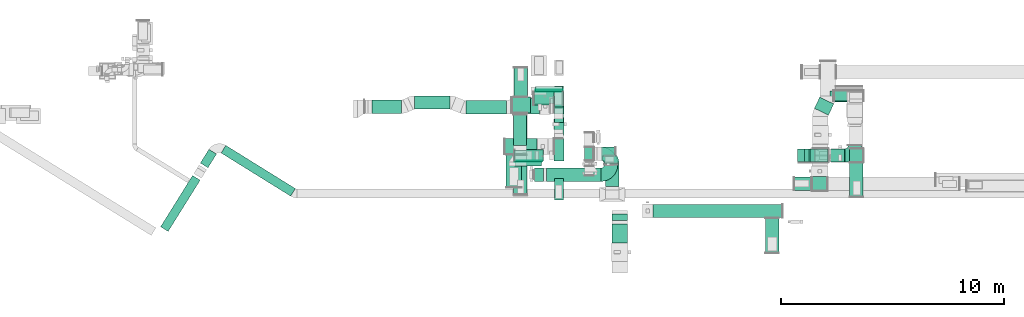
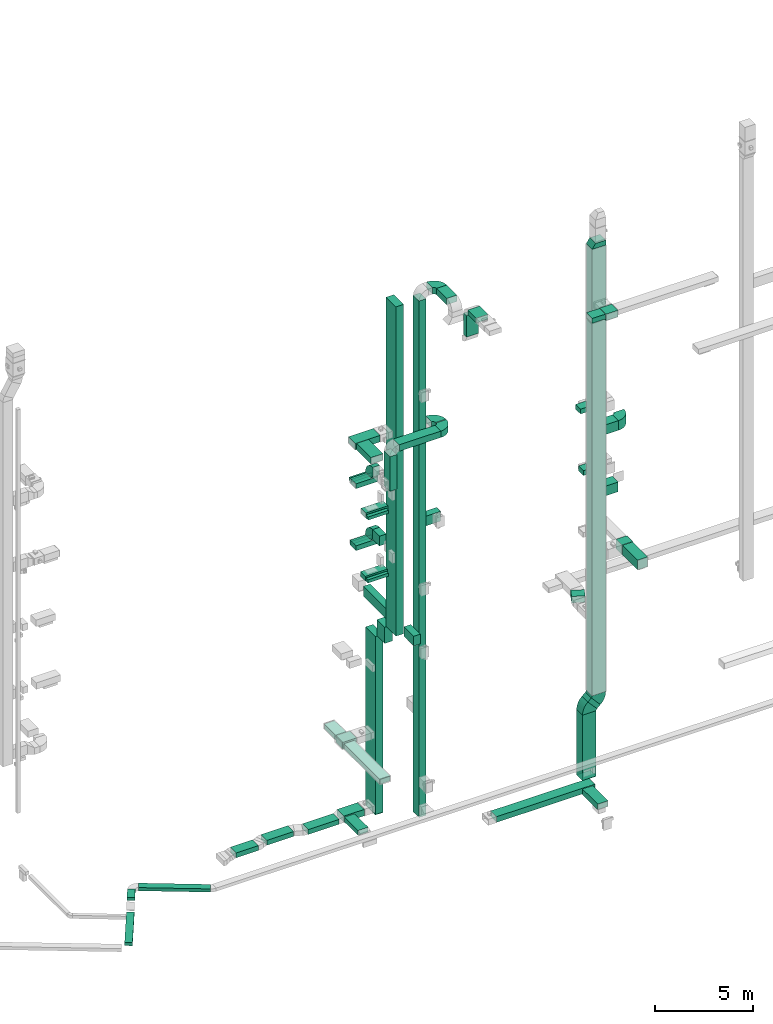
# One storey, part 7 of 25: 47 flow segments, 15 flow fittings.
"""IFC2X3 building model written with IfcOpenShell, lengths in millimetres."""

from ifc_helpers import new_model, entity, si_unit, converted_unit, derived_unit, direction, frame, frame_2d, origin, origin_2d_with_axis, place, context, subcontext, project, spatial, polyline, circle_curve, parameter, trimmed, segment, composite_curve, rectangle, outline, extrude, source, transform, mapped, material, type_object, type_shapes, element, save


model = new_model("IFC2X3")

# Units and contexts
model_context = context("Model", 3, precision=0.01, world=origin(), true_north=direction((6.12303176911189e-17, 1.0)))
body_context = subcontext(model_context, "Body", "Model", "MODEL_VIEW")
ifc_project = project(units=[si_unit("LENGTHUNIT", "METRE", prefix="MILLI"), si_unit("AREAUNIT", "SQUARE_METRE"), si_unit("VOLUMEUNIT", "CUBIC_METRE"), converted_unit("PLANEANGLEUNIT", "DEGREE", entity("IfcRatioMeasure", 0.0174532925199433), si_unit("PLANEANGLEUNIT", "RADIAN"), dimensions=[0, 0, 0, 0, 0, 0, 0]), si_unit("MASSUNIT", "GRAM", prefix="KILO"), derived_unit("MASSDENSITYUNIT", [(si_unit("MASSUNIT", "GRAM", prefix="KILO"), 1), (si_unit("LENGTHUNIT", "METRE"), -3)]), derived_unit("MOMENTOFINERTIAUNIT", [(si_unit("LENGTHUNIT", "METRE"), 4)]), si_unit("TIMEUNIT", "SECOND"), si_unit("FREQUENCYUNIT", "HERTZ"), si_unit("THERMODYNAMICTEMPERATUREUNIT", "DEGREE_CELSIUS"), derived_unit("THERMALTRANSMITTANCEUNIT", [(si_unit("MASSUNIT", "GRAM", prefix="KILO"), 1), (si_unit("THERMODYNAMICTEMPERATUREUNIT", "KELVIN"), -1), (si_unit("TIMEUNIT", "SECOND"), -3)]), derived_unit("VOLUMETRICFLOWRATEUNIT", [(si_unit("LENGTHUNIT", "METRE"), 3), (si_unit("TIMEUNIT", "SECOND"), -1)]), derived_unit("MASSFLOWRATEUNIT", [(si_unit("MASSUNIT", "GRAM", prefix="KILO"), 1), (si_unit("TIMEUNIT", "SECOND"), -1)]), derived_unit("ROTATIONALFREQUENCYUNIT", [(si_unit("TIMEUNIT", "SECOND"), -1)]), si_unit("ELECTRICCURRENTUNIT", "AMPERE"), si_unit("ELECTRICVOLTAGEUNIT", "VOLT"), si_unit("POWERUNIT", "WATT"), si_unit("FORCEUNIT", "NEWTON", prefix="KILO"), si_unit("ILLUMINANCEUNIT", "LUX"), si_unit("LUMINOUSFLUXUNIT", "LUMEN"), si_unit("LUMINOUSINTENSITYUNIT", "CANDELA"), derived_unit("USERDEFINED", [(si_unit("MASSUNIT", "GRAM", prefix="KILO"), -1), (si_unit("LENGTHUNIT", "METRE"), -2), (si_unit("TIMEUNIT", "SECOND"), 3), (si_unit("LUMINOUSFLUXUNIT", "LUMEN"), 1)]), derived_unit("LINEARVELOCITYUNIT", [(si_unit("LENGTHUNIT", "METRE"), 1), (si_unit("TIMEUNIT", "SECOND"), -1)]), si_unit("PRESSUREUNIT", "PASCAL"), derived_unit("USERDEFINED", [(si_unit("LENGTHUNIT", "METRE"), -2), (si_unit("MASSUNIT", "GRAM", prefix="KILO"), 1), (si_unit("TIMEUNIT", "SECOND"), -2)]), derived_unit("LINEARFORCEUNIT", [(si_unit("MASSUNIT", "GRAM", prefix="KILO"), 1), (si_unit("LENGTHUNIT", "METRE"), 1), (si_unit("TIMEUNIT", "SECOND"), -2), (si_unit("LENGTHUNIT", "METRE"), -1)]), derived_unit("PLANARFORCEUNIT", [(si_unit("MASSUNIT", "GRAM", prefix="KILO"), 1), (si_unit("LENGTHUNIT", "METRE"), 1), (si_unit("TIMEUNIT", "SECOND"), -2), (si_unit("LENGTHUNIT", "METRE"), -2)])], contexts=[model_context])

# Site, building, storey
site_placement = place(None, origin())
site = spatial("IfcSite", under=ifc_project, at=site_placement, CompositionType="ELEMENT")
building_placement = place(site_placement, origin())
building = spatial("IfcBuilding", under=site, at=building_placement, CompositionType="ELEMENT")
storey_placement = place(building_placement, origin())
storey = spatial("IfcBuildingStorey", under=building, at=storey_placement, CompositionType="ELEMENT", Elevation=0.0)

# Flow segments
duct_segment_type = type_object("IfcDuctSegmentType", PredefinedType="NOTDEFINED")
flow_segment_1_placement = place(storey_placement, frame((30295.0, 10641.23, 10149.91)))
element("IfcFlowSegment", 1, at=flow_segment_1_placement, inside=storey, type_object=duct_segment_type, context=body_context, shape_type="SweptSolid", body=[
    extrude(rectangle(XDim=1000.0, YDim=450.000000000002, at=frame_2d((0.0, 0.0), x_axis=(0.0, 1.0))), frame((225.0, 500.0, 0.03), z_axis=(0.0, 6.74695346571014e-05, 0.999999997723931), x_axis=(1.0, 0.0, 0.0)), (0.0, 0.0, 1.0), 20435.0083572388),
])
flow_segment_2_placement = place(storey_placement, frame((28145.0, 9460.01, 22300.0)))
element("IfcFlowSegment", 2, at=flow_segment_2_placement, inside=storey, type_object=duct_segment_type, context=body_context, shape_type="SweptSolid", body=[
    extrude(rectangle(XDim=1459.60110156257, YDim=700.000000000001, at=origin_2d_with_axis()), frame((350.0, 729.8, 0.0), z_axis=(0.0, 0.0, 1.0), x_axis=(0.0, 1.0, 0.0)), (0.0, 0.0, 1.0), 399.999999999996),
])
flow_segment_3_placement = place(storey_placement, frame((28539.49, 10419.96, 18100.0)))
element("IfcFlowSegment", 3, at=flow_segment_3_placement, inside=storey, type_object=duct_segment_type, context=body_context, shape_type="SweptSolid", body=[
    extrude(rectangle(XDim=207.424280319602, YDim=1200.0, at=origin_2d_with_axis()), frame((600.0, 103.71, 0.0), z_axis=(0.0, 0.0, 1.0), x_axis=(0.0, 1.0, 0.0)), (0.0, 0.0, 1.0), 199.999999999998),
])
flow_segment_4_placement = place(storey_placement, frame((29469.94, 13762.38, 18100.0)))
element("IfcFlowSegment", 4, at=flow_segment_4_placement, inside=storey, type_object=duct_segment_type, context=body_context, shape_type="SweptSolid", body=[
    extrude(rectangle(XDim=213.642800178943, YDim=1200.0, at=origin_2d_with_axis()), frame((600.0, 106.82, 0.0), z_axis=(0.0, 0.0, 1.0), x_axis=(0.0, -1.0, 0.0)), (0.0, 0.0, 1.0), 199.999999999998),
])
flow_segment_5_placement = place(storey_placement, frame((30320.0, 12362.75, 14700.0)))
element("IfcFlowSegment", 5, at=flow_segment_5_placement, inside=storey, type_object=duct_segment_type, context=body_context, shape_type="SweptSolid", body=[
    extrude(rectangle(XDim=693.273501355955, YDim=400.0, at=origin_2d_with_axis()), frame((200.0, 346.64, 0.0), z_axis=(0.0, 0.0, 1.0), x_axis=(0.0, 1.0, 0.0)), (0.0, 0.0, 1.0), 600.000000000002),
])
flow_segment_6_placement = place(storey_placement, frame((28529.49, 10419.96, 14200.0)))
element("IfcFlowSegment", 6, at=flow_segment_6_placement, inside=storey, type_object=duct_segment_type, context=body_context, shape_type="SweptSolid", body=[
    extrude(rectangle(XDim=187.424280319602, YDim=1200.0, at=origin_2d_with_axis()), frame((600.0, 93.71, 0.0), z_axis=(0.0, 0.0, 1.0), x_axis=(0.0, 1.0, 0.0)), (0.0, 0.0, 1.0), 199.999999999998),
])
flow_segment_7_placement = place(storey_placement, frame((30295.0, 12737.72, -2200.0)))
element("IfcFlowSegment", 7, at=flow_segment_7_placement, inside=storey, type_object=duct_segment_type, context=body_context, shape_type="SweptSolid", body=[
    extrude(rectangle(XDim=1000.0, YDim=450.000000000002, at=origin_2d_with_axis()), frame((225.0, 500.0, 0.0), z_axis=(0.0, 0.0, 1.0), x_axis=(0.0, 1.0, 0.0)), (0.0, 0.0, 1.0), 11049.8972385017),
])
flow_segment_8_placement = place(storey_placement, frame((30295.0, 11791.17, 8999.9)))
element("IfcFlowSegment", 8, at=flow_segment_8_placement, inside=storey, type_object=duct_segment_type, context=body_context, shape_type="SweptSolid", body=[
    extrude(rectangle(XDim=796.553849855163, YDim=450.000000000002, at=origin_2d_with_axis()), frame((225.0, 398.28, 0.0), z_axis=(0.0, 0.0, 1.0), x_axis=(0.0, -1.0, 0.0)), (0.0, 0.0, 1.0), 999.999999999999),
])
flow_segment_9_placement = place(storey_placement, frame((30319.23, 8881.06, 10600.0)))
element("IfcFlowSegment", 9, at=flow_segment_9_placement, inside=storey, type_object=duct_segment_type, context=body_context, shape_type="SweptSolid", body=[
    extrude(rectangle(XDim=979.162023649434, YDim=400.0, at=origin_2d_with_axis()), frame((200.0, 489.58, 0.0), z_axis=(0.0, 0.0, 1.0), x_axis=(0.0, -1.0, 0.0)), (0.0, 0.0, 1.0), 600.000000000002),
])
flow_segment_10_placement = place(storey_placement, frame((30320.0, 11661.3, 10600.0)))
element("IfcFlowSegment", 10, at=flow_segment_10_placement, inside=storey, type_object=duct_segment_type, context=body_context, shape_type="SweptSolid", body=[
    extrude(rectangle(XDim=2339.00060690553, YDim=400.0, at=origin_2d_with_axis()), frame((200.0, 1169.5, 0.0), z_axis=(0.0, 0.0, 1.0), x_axis=(0.0, 1.0, 0.0)), (0.0, 0.0, 1.0), 600.000000000002),
])
flow_segment_11_placement = place(storey_placement, frame((28415.0, 12797.72, 2500.0)))
element("IfcFlowSegment", 11, at=flow_segment_11_placement, inside=storey, type_object=duct_segment_type, context=body_context, shape_type="SweptSolid", body=[
    extrude(rectangle(XDim=825.107316474216, YDim=700.000000000001, at=origin_2d_with_axis()), frame((412.55, 350.0, 0.0), z_axis=(0.0, 0.0, 1.0), x_axis=(-1.0, 0.0, 0.0)), (0.0, 0.0, 1.0), 400.0),
])
flow_segment_12_placement = place(storey_placement, frame((28501.05, 13517.72, 2500.0)))
element("IfcFlowSegment", 12, at=flow_segment_12_placement, inside=storey, type_object=duct_segment_type, context=body_context, shape_type="SweptSolid", body=[
    extrude(rectangle(XDim=1299.51814618853, YDim=600.000000000002, at=origin_2d_with_axis()), frame((300.0, 649.76, 0.0), z_axis=(0.0, 0.0, 1.0), x_axis=(0.0, 1.0, 0.0)), (0.0, 0.0, 1.0), 300.0),
])
flow_segment_13_placement = place(storey_placement, frame((28489.1, 9142.08, 2500.0)))
element("IfcFlowSegment", 13, at=flow_segment_13_placement, inside=storey, type_object=duct_segment_type, context=body_context, shape_type="SweptSolid", body=[
    extrude(rectangle(XDim=3635.64597304317, YDim=599.999999999998, at=origin_2d_with_axis()), frame((300.0, 1817.82, 0.0), z_axis=(0.0, 0.0, 1.0), x_axis=(0.0, -1.0, 0.0)), (0.0, 0.0, 1.0), 300.0),
])
flow_segment_14_placement = place(storey_placement, frame((15376.52, 9062.76, -650.0)))
element("IfcFlowSegment", 14, at=flow_segment_14_placement, inside=storey, type_object=duct_segment_type, context=body_context, shape_type="SweptSolid", body=[
    extrude(rectangle(XDim=3668.63374215352, YDim=400.0, at=origin_2d_with_axis()), frame((1663.81, 1137.59, 0.0), z_axis=(0.0, 0.0, 1.0), x_axis=(-0.849526449943789, 0.527546027229761, 0.0)), (0.0, 0.0, 1.0), 200.0),
])
flow_segment_15_placement = place(storey_placement, frame((14446.28, 10334.57, -650.0)))
element("IfcFlowSegment", 15, at=flow_segment_15_placement, inside=storey, type_object=duct_segment_type, context=body_context, shape_type="SweptSolid", body=[
    extrude(rectangle(XDim=725.928935333944, YDim=399.999999999999, at=origin_2d_with_axis()), frame((361.95, 413.8, 0.0), z_axis=(0.0, 0.0, 1.0), x_axis=(-0.529919263980747, -0.84804809631418, 0.0)), (0.0, 0.0, 1.0), 200.0),
])
flow_segment_16_placement = place(storey_placement, frame((32609.02, 9486.91, 30605.49)))
element("IfcFlowSegment", 16, at=flow_segment_16_placement, inside=storey, type_object=duct_segment_type, context=body_context, shape_type="SweptSolid", body=[
    extrude(rectangle(XDim=1028.1825294501, YDim=600.000000000002, at=origin_2d_with_axis()), frame((300.0, 514.09, 0.0), z_axis=(0.0, 0.0, 1.0), x_axis=(0.0, 1.0, 0.0)), (0.0, 0.0, 1.0), 400.000000000004),
])
flow_segment_17_placement = place(storey_placement, frame((31669.87, 10665.1, -1605.0)))
element("IfcFlowSegment", 17, at=flow_segment_17_placement, inside=storey, type_object=duct_segment_type, context=body_context, shape_type="SweptSolid", body=[
    extrude(rectangle(XDim=600.000000000002, YDim=400.0, at=origin_2d_with_axis()), frame((200.0, 300.0, 0.0), z_axis=(0.0, 0.0, 1.0), x_axis=(0.0, -1.0, 0.0)), (0.0, 0.0, 1.0), 32060.4908940358),
])
flow_segment_18_placement = place(storey_placement, frame((29965.56, 9724.94, 22300.0)))
element("IfcFlowSegment", 18, at=flow_segment_18_placement, inside=storey, type_object=duct_segment_type, context=body_context, shape_type="SweptSolid", body=[
    extrude(rectangle(XDim=2439.64261880375, YDim=600.000000000001, at=origin_2d_with_axis()), frame((1219.82, 300.0, 0.0), z_axis=(0.0, 0.0, 1.0), x_axis=(-1.0, 0.0, 0.0)), (0.0, 0.0, 1.0), 399.999999999996),
])
flow_segment_19_placement = place(storey_placement, frame((29415.56, 9724.94, 20000.0)))
element("IfcFlowSegment", 19, at=flow_segment_19_placement, inside=storey, type_object=duct_segment_type, context=body_context, shape_type="SweptSolid", body=[
    extrude(rectangle(XDim=599.999999999999, YDim=400.0, at=origin_2d_with_axis()), frame((200.0, 300.0, 0.0), z_axis=(0.0, 0.0, 1.0), x_axis=(0.0, 1.0, 0.0)), (0.0, 0.0, 1.0), 2150.00000000004),
])
flow_segment_20_placement = place(storey_placement, frame((32089.87, 10865.1, 16200.0)))
element("IfcFlowSegment", 20, at=flow_segment_20_placement, inside=storey, type_object=duct_segment_type, context=body_context, shape_type="SweptSolid", body=[
    extrude(rectangle(XDim=954.155014258539, YDim=400.0, at=origin_2d_with_axis()), frame((477.08, 200.0, 0.0)), (0.0, 0.0, 1.0), 600.000000000002),
])
flow_segment_21_placement = place(storey_placement, frame((34735.4, 8100.0, -1425.0)))
element("IfcFlowSegment", 21, at=flow_segment_21_placement, inside=storey, type_object=duct_segment_type, context=body_context, shape_type="SweptSolid", body=[
    extrude(rectangle(XDim=5780.0, YDim=600.0, at=origin_2d_with_axis()), frame((2890.0, 300.0, 0.0), z_axis=(0.0, 0.0, 1.0), x_axis=(-1.0, 0.0, 0.0)), (0.0, 0.0, 1.0), 350.0),
])
flow_segment_22_placement = place(storey_placement, frame((39770.17, 6532.87, -1450.0)))
element("IfcFlowSegment", 22, at=flow_segment_22_placement, inside=storey, type_object=duct_segment_type, context=body_context, shape_type="SweptSolid", body=[
    extrude(rectangle(XDim=1547.13469734111, YDim=600.000000000002, at=origin_2d_with_axis()), frame((300.0, 773.57, 0.0), z_axis=(0.0, 0.0, 1.0), x_axis=(0.0, 1.0, 0.0)), (0.0, 0.0, 1.0), 350.0),
])
flow_segment_23_placement = place(storey_placement, frame((32894.02, 6972.96, 30900.0)))
element("IfcFlowSegment", 23, at=flow_segment_23_placement, inside=storey, type_object=duct_segment_type, context=body_context, shape_type="SweptSolid", body=[
    extrude(rectangle(XDim=847.952898202239, YDim=700.000000000001, at=origin_2d_with_axis()), frame((350.0, 423.98, 0.0), z_axis=(0.0, 0.0, 1.0), x_axis=(0.0, -1.0, 0.0)), (0.0, 0.0, 1.0), 300.000000000001),
])
flow_segment_24_placement = place(storey_placement, frame((32894.02, 7970.91, 29420.0)))
element("IfcFlowSegment", 24, at=flow_segment_24_placement, inside=storey, type_object=duct_segment_type, context=body_context, shape_type="SweptSolid", body=[
    extrude(rectangle(XDim=299.999999999999, YDim=700.000000000001, at=origin_2d_with_axis()), frame((350.0, 150.0, 0.0), z_axis=(0.0, 0.0, 1.0), x_axis=(0.0, 1.0, 0.0)), (0.0, 0.0, 1.0), 1330.00000000001),
])
flow_segment_25_placement = place(storey_placement, frame((42604.87, 10584.99, 18400.0)))
element("IfcFlowSegment", 25, at=flow_segment_25_placement, inside=storey, type_object=duct_segment_type, context=body_context, shape_type="SweptSolid", body=[
    extrude(rectangle(XDim=725.674377856759, YDim=600.0, at=origin_2d_with_axis()), frame((362.84, 300.0, 0.0)), (0.0, 0.0, 1.0), 600.000000000002),
])
flow_segment_26_placement = place(storey_placement, frame((43542.97, 10584.99, 10600.0)))
element("IfcFlowSegment", 26, at=flow_segment_26_placement, inside=storey, type_object=duct_segment_type, context=body_context, shape_type="SweptSolid", body=[
    extrude(rectangle(XDim=621.895575496119, YDim=600.0, at=origin_2d_with_axis()), frame((310.95, 300.0, 0.0)), (0.0, 0.0, 1.0), 599.999999999998),
])
flow_segment_27_placement = place(storey_placement, frame((43550.6, 9032.79, 10600.0)))
element("IfcFlowSegment", 27, at=flow_segment_27_placement, inside=storey, type_object=duct_segment_type, context=body_context, shape_type="SweptSolid", body=[
    extrude(rectangle(XDim=1532.19867734506, YDim=600.000000000002, at=origin_2d_with_axis()), frame((300.0, 766.1, 0.0), z_axis=(0.0, 0.0, 1.0), x_axis=(0.0, 1.0, 0.0)), (0.0, 0.0, 1.0), 600.000000000002),
])
flow_segment_28_placement = place(storey_placement, frame((42667.67, 13287.49, 18000.0)))
element("IfcFlowSegment", 28, at=flow_segment_28_placement, inside=storey, type_object=duct_segment_type, context=body_context, shape_type="SweptSolid", body=[
    extrude(rectangle(XDim=1480.0, YDim=499.999999999999, at=origin_2d_with_axis()), frame((740.0, 250.0, 0.0)), (0.0, 0.0, 1.0), 300.000000000001),
])
flow_segment_29_placement = place(storey_placement, frame((42847.67, 13317.49, 14100.0)))
element("IfcFlowSegment", 29, at=flow_segment_29_placement, inside=storey, type_object=duct_segment_type, context=body_context, shape_type="SweptSolid", body=[
    extrude(rectangle(XDim=1300.00000000001, YDim=499.999999999999, at=origin_2d_with_axis()), frame((650.0, 250.0, 0.0), z_axis=(0.0, 0.0, 1.0), x_axis=(-1.0, 0.0, 0.0)), (0.0, 0.0, 1.0), 300.000000000001),
])
flow_segment_30_placement = place(storey_placement, frame((41966.37, 12696.43, 6700.0)))
element("IfcFlowSegment", 30, at=flow_segment_30_placement, inside=storey, type_object=duct_segment_type, context=body_context, shape_type="SweptSolid", body=[
    extrude(rectangle(XDim=554.821864390223, YDim=700.000000000004, at=origin_2d_with_axis()), frame((435.33, 401.07, 0.0), z_axis=(0.0, 0.0, 1.0), x_axis=(0.430524152786573, 0.902579056851755, 0.0)), (0.0, 0.0, 1.0), 400.0),
])
flow_segment_31_placement = place(storey_placement, frame((41218.87, 10584.99, -2600.0)))
element("IfcFlowSegment", 31, at=flow_segment_31_placement, inside=storey, type_object=duct_segment_type, context=body_context, shape_type="SweptSolid", body=[
    extrude(rectangle(XDim=599.999999999998, YDim=800.0, at=origin_2d_with_axis()), frame((400.0, 300.0, 0.0), z_axis=(0.0, 0.0, 1.0), x_axis=(0.0, -1.0, 0.0)), (0.0, 0.0, 1.0), 4055.12422308032),
])
flow_segment_32_placement = place(storey_placement, frame((41533.2, 10584.99, 1566.6)))
element("IfcFlowSegment", 32, at=flow_segment_32_placement, inside=storey, type_object=duct_segment_type, context=body_context, shape_type="SweptSolid", body=[
    extrude(rectangle(XDim=271.865207514505, YDim=600.0, at=origin_2d_with_axis()), frame((636.32, 300.0, 90.96), z_axis=(-0.669130606358778, 0.0, 0.743144825477467), x_axis=(-0.743144825477467, 0.0, -0.669130606358778)), (0.0, 0.0, 1.0), 799.999999999999),
])
flow_segment_33_placement = place(storey_placement, frame((41784.87, 10584.99, 2454.5)))
element("IfcFlowSegment", 33, at=flow_segment_33_placement, inside=storey, type_object=duct_segment_type, context=body_context, shape_type="SweptSolid", body=[
    extrude(rectangle(XDim=799.999999999991, YDim=600.0, at=origin_2d_with_axis()), frame((400.0, 300.0, 0.0)), (0.0, 0.0, 1.0), 27715.1242230804),
])
flow_segment_34_placement = place(storey_placement, frame((41854.87, 9297.2, 26500.0)))
element("IfcFlowSegment", 34, at=flow_segment_34_placement, inside=storey, type_object=duct_segment_type, context=body_context, shape_type="SweptSolid", body=[
    extrude(rectangle(XDim=648.296900313846, YDim=699.999999999997, at=origin_2d_with_axis()), frame((350.0, 324.15, 0.0), z_axis=(0.0, 0.0, 1.0), x_axis=(0.0, 1.0, 0.0)), (0.0, 0.0, 1.0), 400.000000000004),
])
flow_segment_35_placement = place(storey_placement, frame((42604.87, 10584.99, 14600.0)))
element("IfcFlowSegment", 35, at=flow_segment_35_placement, inside=storey, type_object=duct_segment_type, context=body_context, shape_type="SweptSolid", body=[
    extrude(rectangle(XDim=705.39385088537, YDim=600.0, at=origin_2d_with_axis()), frame((352.7, 300.0, 0.0), z_axis=(0.0, 0.0, 1.0), x_axis=(-1.0, 0.0, 0.0)), (0.0, 0.0, 1.0), 600.000000000002),
])
flow_segment_36_placement = place(storey_placement, frame((41055.98, 9319.58, 26600.0)))
element("IfcFlowSegment", 36, at=flow_segment_36_placement, inside=storey, type_object=duct_segment_type, context=body_context, shape_type="SweptSolid", body=[
    extrude(rectangle(XDim=778.881621530124, YDim=600.0, at=origin_2d_with_axis()), frame((389.44, 300.0, 0.0)), (0.0, 0.0, 1.0), 300.000000000001),
])
flow_segment_37_placement = place(storey_placement, frame((12662.92, 7480.6, -1100.0)))
element("IfcFlowSegment", 37, at=flow_segment_37_placement, inside=storey, type_object=duct_segment_type, context=body_context, shape_type="SweptSolid", body=[
    extrude(rectangle(XDim=2708.23797397184, YDim=400.0, at=origin_2d_with_axis()), frame((887.18, 1254.34, 0.0), z_axis=(0.0, 0.0, 1.0), x_axis=(0.529919264233212, 0.848048096156422, 0.0)), (0.0, 0.0, 1.0), 200.0),
])
for number, where in (
    (38, (28533.94, 10647.38, 18100.0)),
    (39, (28493.94, 10627.38, 14200.0)),
):
    element("IfcFlowSegment", number, at=place(storey_placement, frame(where)), inside=storey, type_object=duct_segment_type, context=body_context, shape_type="SweptSolid", body=[
        extrude(rectangle(XDim=1300.0, YDim=500.000000000001, at=origin_2d_with_axis()), frame((650.0, 250.0, 0.0), z_axis=(0.0, 0.0, 1.0), x_axis=(-1.0, 0.0, 0.0)), (0.0, 0.0, 1.0), 300.000000000001),
    ])
flow_segment_38_placement = place(storey_placement, frame((28095.0, 10939.62, 22300.0)))
element("IfcFlowSegment", 40, at=flow_segment_38_placement, inside=storey, type_object=duct_segment_type, context=body_context, shape_type="SweptSolid", body=[
    extrude(rectangle(XDim=1448.90399999998, YDim=699.999999999999, at=origin_2d_with_axis()), frame((724.45, 350.0, 0.0), z_axis=(0.0, 0.0, 1.0), x_axis=(-1.0, 0.0, 0.0)), (0.0, 0.0, 1.0), 399.999999999996),
])
flow_segment_39_placement = place(storey_placement, frame((29430.94, 13206.02, 14200.0)))
element("IfcFlowSegment", 41, at=flow_segment_39_placement, inside=storey, type_object=duct_segment_type, context=body_context, shape_type="SweptSolid", body=[
    extrude(rectangle(XDim=1300.0, YDim=600.0, at=origin_2d_with_axis()), frame((650.0, 300.0, 0.0), z_axis=(0.0, 0.0, 1.0), x_axis=(-1.0, 0.0, 0.0)), (0.0, 0.0, 1.0), 300.000000000001),
])
flow_segment_40_placement = place(storey_placement, frame((26358.06, 12739.72, -2050.0)))
element("IfcFlowSegment", 42, at=flow_segment_40_placement, inside=storey, type_object=duct_segment_type, context=body_context, shape_type="SweptSolid", body=[
    extrude(rectangle(XDim=1804.93628128251, YDim=600.0, at=origin_2d_with_axis()), frame((902.47, 300.0, 0.0)), (0.0, 0.0, 1.0), 300.0),
])
flow_segment_41_placement = place(storey_placement, frame((24052.03, 12959.72, -2050.0)))
element("IfcFlowSegment", 43, at=flow_segment_41_placement, inside=storey, type_object=duct_segment_type, context=body_context, shape_type="SweptSolid", body=[
    extrude(rectangle(XDim=1575.26738871717, YDim=600.0, at=origin_2d_with_axis()), frame((787.63, 300.0, 0.0), z_axis=(0.0, 0.0, 1.0), x_axis=(-1.0, 0.0, 0.0)), (0.0, 0.0, 1.0), 300.0),
])
flow_segment_42_placement = place(storey_placement, frame((28463.0, 12739.72, -2050.0)))
element("IfcFlowSegment", 44, at=flow_segment_42_placement, inside=storey, type_object=duct_segment_type, context=body_context, shape_type="SweptSolid", body=[
    extrude(rectangle(XDim=1192.54293478417, YDim=699.999999999999, at=origin_2d_with_axis()), frame((596.27, 350.0, 0.0), z_axis=(0.0, 0.0, 1.0), x_axis=(-1.0, 0.0, 0.0)), (0.0, 0.0, 1.0), 400.0),
])
flow_segment_43_placement = place(storey_placement, frame((28469.95, 11337.31, -2000.0)))
element("IfcFlowSegment", 45, at=flow_segment_43_placement, inside=storey, type_object=duct_segment_type, context=body_context, shape_type="SweptSolid", body=[
    extrude(rectangle(XDim=1382.41385794984, YDim=599.999999999998, at=origin_2d_with_axis()), frame((300.0, 691.21, 0.0), z_axis=(0.0, 0.0, 1.0), x_axis=(0.0, -1.0, 0.0)), (0.0, 0.0, 1.0), 300.0),
])
flow_segment_44_placement = place(storey_placement, frame((22148.7, 12774.72, -2050.0)))
element("IfcFlowSegment", 46, at=flow_segment_44_placement, inside=storey, type_object=duct_segment_type, context=body_context, shape_type="SweptSolid", body=[
    extrude(rectangle(XDim=1311.81183901042, YDim=600.0, at=origin_2d_with_axis()), frame((655.91, 300.0, 0.0)), (0.0, 0.0, 1.0), 300.0),
])
flow_segment_45_placement = place(storey_placement, frame((29393.94, 13142.38, 18100.0)))
element("IfcFlowSegment", 47, at=flow_segment_45_placement, inside=storey, type_object=duct_segment_type, context=body_context, shape_type="SweptSolid", body=[
    extrude(rectangle(XDim=1300.0, YDim=600.0, at=origin_2d_with_axis()), frame((650.0, 300.0, 0.0), z_axis=(0.0, 0.0, 1.0), x_axis=(-1.0, 0.0, 0.0)), (0.0, 0.0, 1.0), 300.000000000001),
])

# Flow fittings
ifc_material = material()
duct_fitting_type_1 = type_object("IfcDuctFittingType", PredefinedType="NOTDEFINED", material=ifc_material)
shared_shape_1 = source(origin(), body_context, "Body", "SweptSolid", [
    extrude(rectangle(XDim=24.9999999999999, YDim=1000.0, at=origin_2d_with_axis()), frame((12.5, 0.0, -225.0)), (0.0, 0.0, 1.0), 450.0),
])
type_shapes(duct_fitting_type_1, [shared_shape_1])
flow_fitting_1_placement = place(storey_placement, frame((30520.0, 13237.72, -2200.0), z_axis=(-1.0, 0.0, 0.0), x_axis=(0.0, 0.0, -1.0)))
element("IfcFlowFitting", 48, at=flow_fitting_1_placement, inside=storey, type_object=duct_fitting_type_1, material=ifc_material, context=body_context, shape_type="MappedRepresentation", body=[
    mapped(shared_shape_1, transform((0.0, 0.0, 0.0), scale=1.0)),
])
duct_fitting_type_2 = type_object("IfcDuctFittingType", PredefinedType="NOTDEFINED", material=ifc_material)
shared_shape_2 = source(origin(), body_context, "Body", "SweptSolid", [
    extrude(rectangle(XDim=24.9999999999999, YDim=600.0, at=origin_2d_with_axis()), frame((12.5, 0.0, -400.0)), (0.0, 0.0, 1.0), 800.0),
])
type_shapes(duct_fitting_type_2, [shared_shape_2])
flow_fitting_2_placement = place(storey_placement, frame((41618.87, 10884.99, -2600.0), z_axis=(1.0, 0.0, 0.0), x_axis=(0.0, 0.0, -1.0)))
element("IfcFlowFitting", 49, at=flow_fitting_2_placement, inside=storey, type_object=duct_fitting_type_2, material=ifc_material, context=body_context, shape_type="MappedRepresentation", body=[
    mapped(shared_shape_2, transform((0.0, 0.0, 0.0), scale=1.0)),
])
duct_fitting_type_3 = type_object("IfcDuctFittingType", PredefinedType="NOTDEFINED", material=ifc_material)
shared_shape_3 = source(origin(), body_context, "Body", "SweptSolid", [
    extrude(rectangle(XDim=26.0960000000062, YDim=1200.0, at=origin_2d_with_axis()), frame((6.95, 0.0, -100.0)), (0.0, 0.0, 1.0), 200.0),
])
type_shapes(duct_fitting_type_3, [shared_shape_3])
for number, where, z_axis, x_axis in (
    (50, (29129.49, 10627.38, 14300.0), (0.0, 0.0, -1.0), (0.0, -1.0, 0.0)),
    (51, (30080.94, 13806.02, 14300.0), (0.0, 0.0, -1.0), (0.0, 1.0, 0.0)),
    (52, (30069.94, 13742.38, 18200.0), (0.0, 0.0, 1.0), (0.0, 1.0, 0.0)),
    (53, (29139.49, 10647.38, 18200.0), (0.0, 0.0, 1.0), (0.0, -1.0, 0.0)),
):
    element("IfcFlowFitting", number, at=place(storey_placement, frame(where, z_axis=z_axis, x_axis=x_axis)), inside=storey, type_object=duct_fitting_type_3, material=ifc_material, context=body_context, shape_type="MappedRepresentation", body=[
        mapped(shared_shape_3, transform((0.0, 0.0, 0.0), scale=1.0)),
    ])
duct_fitting_type_4 = type_object("IfcDuctFittingType", PredefinedType="NOTDEFINED", material=ifc_material)
shared_shape_4 = source(origin(), body_context, "Body", "SweptSolid", [
    extrude(outline(polyline([(-150.0, -350.0), (150.0, -350.0), (150.0, 250.0), (-150.0, 450.0), (-150.0, -350.0)])), frame((150.0, -300.0, 50.0), z_axis=(0.0, 1.0, 0.0), x_axis=(1.0, 0.0, 0.0)), (0.0, 0.0, 1.0), 600.0),
])
type_shapes(duct_fitting_type_4, [shared_shape_4])
flow_fitting_3_placement = place(storey_placement, frame((42184.87, 10884.99, 30169.62), z_axis=(1.0, 0.0, 0.0), x_axis=(0.0, 0.0, 1.0)))
element("IfcFlowFitting", 54, at=flow_fitting_3_placement, inside=storey, type_object=duct_fitting_type_4, material=ifc_material, context=body_context, shape_type="MappedRepresentation", body=[
    mapped(shared_shape_4, transform((0.0, 0.0, 0.0), scale=1.0)),
])
duct_fitting_type_5 = type_object("IfcDuctFittingType", PredefinedType="NOTDEFINED", material=ifc_material)
shared_shape_5 = source(origin(), body_context, "Body", "SweptSolid", [
    extrude(outline(composite_curve([segment(polyline([(-525.0, -225.0), (75.0, -225.0)]), True, "CONTINUOUS"), segment(trimmed(circle_curve(frame_2d((225.0, -225.0), x_axis=(0.0, 1.0)), 150.0), [parameter(0.0)], [parameter(90.0)], True, "PARAMETER"), False, "CONTINUOUS"), segment(polyline([(225.0, -75.0), (225.0, 525.0)]), True, "CONTINUOUS"), segment(trimmed(circle_curve(frame_2d((225.0, -225.0), x_axis=(0.0, 1.0)), 750.0), [parameter(0.0)], [parameter(90.0)], True, "PARAMETER"), True, "CONTINUOUS")], self_intersect=False)), frame((-225.0, 225.0, -200.0), z_axis=(0.0, 0.0, 1.0), x_axis=(-1.0, 0.0, 0.0)), (0.0, 0.0, 1.0), 400.0),
])
type_shapes(duct_fitting_type_5, [shared_shape_5])
flow_fitting_4_placement = place(storey_placement, frame((32855.21, 10965.1, 22500.0), z_axis=(0.0, 0.0, 1.0), x_axis=(0.0, 1.0, 0.0)))
element("IfcFlowFitting", 55, at=flow_fitting_4_placement, inside=storey, type_object=duct_fitting_type_5, material=ifc_material, context=body_context, shape_type="MappedRepresentation", body=[
    mapped(shared_shape_5, transform((0.0, 0.0, 0.0), scale=1.0)),
])
flow_fitting_5_placement = place(storey_placement, frame((32855.21, 10024.94, 22500.0)))
element("IfcFlowFitting", 56, at=flow_fitting_5_placement, inside=storey, type_object=duct_fitting_type_5, material=ifc_material, context=body_context, shape_type="MappedRepresentation", body=[
    mapped(shared_shape_5, transform((0.0, 0.0, 0.0), scale=1.0)),
])
flow_fitting_6_placement = place(storey_placement, frame((32909.02, 10965.1, 30805.49), z_axis=(0.0, 0.0, 1.0), x_axis=(0.0, 1.0, 0.0)))
element("IfcFlowFitting", 57, at=flow_fitting_6_placement, inside=storey, type_object=duct_fitting_type_5, material=ifc_material, context=body_context, shape_type="MappedRepresentation", body=[
    mapped(shared_shape_5, transform((0.0, 0.0, 0.0), scale=1.0)),
])
duct_fitting_type_6 = type_object("IfcDuctFittingType", PredefinedType="NOTDEFINED", material=ifc_material)
type_shapes(duct_fitting_type_6, [shared_shape_5])
for number, where, z_axis, x_axis in (
    (58, (30520.0, 13506.02, 15000.0), (-1.0, 0.0, 0.0), (0.0, 1.0, 0.0)),
    (59, (30495.0, 13442.38, 18900.0), (-1.0, 0.0, 0.0), (0.0, 1.0, 0.0)),
):
    element("IfcFlowFitting", number, at=place(storey_placement, frame(where, z_axis=z_axis, x_axis=x_axis)), inside=storey, type_object=duct_fitting_type_6, material=ifc_material, context=body_context, shape_type="MappedRepresentation", body=[
        mapped(shared_shape_5, transform((0.0, 0.0, 0.0), scale=1.0)),
    ])
duct_fitting_type_7 = type_object("IfcDuctFittingType", PredefinedType="NOTDEFINED", material=ifc_material)
shared_shape_6 = source(origin(), body_context, "Body", "SweptSolid", [
    extrude(outline(composite_curve([segment(polyline([(-490.99, -204.36), (309.01, -204.36)]), True, "CONTINUOUS"), segment(trimmed(circle_curve(frame_2d((459.01, -204.36), x_axis=(-0.669130606358806, 0.74314482547743)), 150.0), [parameter(0.0)], [parameter(48.0000000000037)], True, "PARAMETER"), False, "CONTINUOUS"), segment(polyline([(358.64, -92.89), (-176.66, 501.62)]), True, "CONTINUOUS"), segment(trimmed(circle_curve(frame_2d((459.01, -204.36), x_axis=(-0.669130606358806, 0.74314482547743)), 950.0), [parameter(0.0)], [parameter(48.0000000000037)], True, "PARAMETER"), True, "CONTINUOUS")], self_intersect=False)), frame((-40.51, 90.99, -300.0), z_axis=(0.0, 0.0, 1.0), x_axis=(-0.743144825477437, 0.669130606358811, 0.0)), (0.0, 0.0, 1.0), 600.0),
])
type_shapes(duct_fitting_type_7, [shared_shape_6])
for number, where, z_axis, x_axis in (
    (60, (41618.87, 10884.99, 1700.0), (0.0, 1.0, 0.0), (0.0, 0.0, 1.0)),
    (61, (42184.87, 10884.99, 2209.62), (0.0, -1.0, 0.0), (0.743144825477466, 0.0, 0.669130606358779)),
):
    element("IfcFlowFitting", number, at=place(storey_placement, frame(where, z_axis=z_axis, x_axis=x_axis)), inside=storey, type_object=duct_fitting_type_7, material=ifc_material, context=body_context, shape_type="MappedRepresentation", body=[
        mapped(shared_shape_6, transform((0.0, 0.0, 0.0), scale=1.0)),
    ])
duct_fitting_type_8 = type_object("IfcDuctFittingType", PredefinedType="NOTDEFINED", material=ifc_material)
shared_shape_7 = source(origin(), body_context, "Body", "SweptSolid", [
    extrude(outline(composite_curve([segment(polyline([(-525.0, -225.0), (75.0, -225.0)]), True, "CONTINUOUS"), segment(trimmed(circle_curve(frame_2d((225.0, -225.0), x_axis=(0.0, 1.0)), 150.0), [parameter(0.0)], [parameter(90.0)], True, "PARAMETER"), False, "CONTINUOUS"), segment(polyline([(225.0, -75.0), (225.0, 525.0)]), True, "CONTINUOUS"), segment(trimmed(circle_curve(frame_2d((225.0, -225.0), x_axis=(0.0, 1.0)), 750.0), [parameter(0.0)], [parameter(90.0)], True, "PARAMETER"), True, "CONTINUOUS")], self_intersect=False)), frame((-225.0, 225.0, -300.0), z_axis=(0.0, 0.0, 1.0), x_axis=(-1.0, 0.0, 0.0)), (0.0, 0.0, 1.0), 600.0),
])
type_shapes(duct_fitting_type_8, [shared_shape_7])
flow_fitting_7_placement = place(storey_placement, frame((43780.54, 10884.99, 18700.0)))
element("IfcFlowFitting", 62, at=flow_fitting_7_placement, inside=storey, type_object=duct_fitting_type_8, material=ifc_material, context=body_context, shape_type="MappedRepresentation", body=[
    mapped(shared_shape_7, transform((0.0, 0.0, 0.0), scale=1.0)),
])

save(model, "model.ifc")
